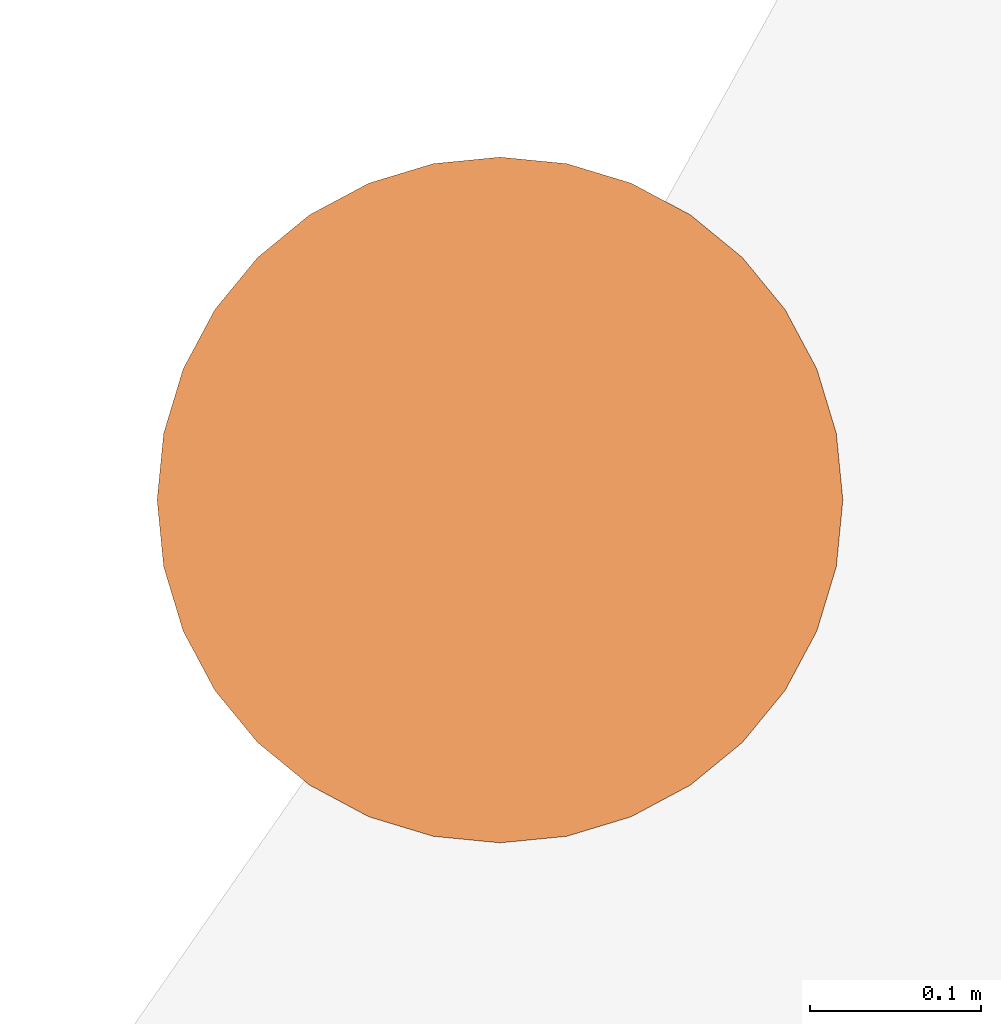
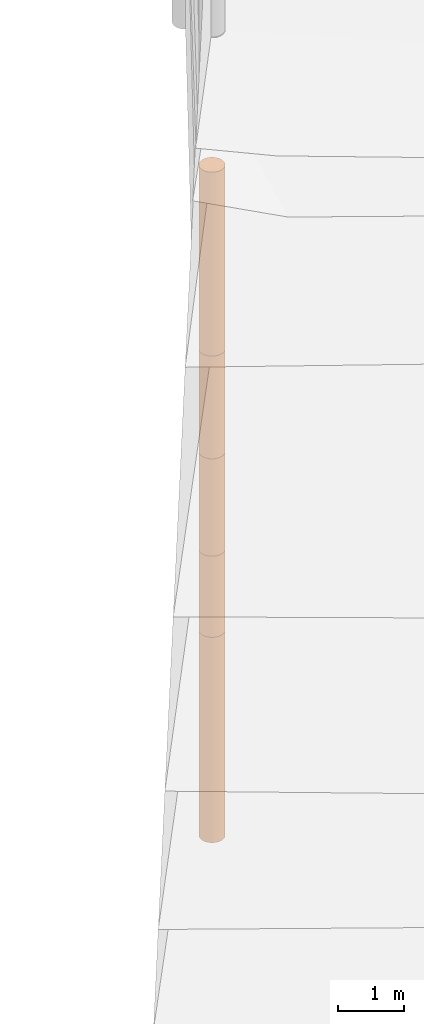
# One storey, part 8 of 24: 5 geographic elements.
"""IFC4 building model written with IfcOpenShell, lengths in metres."""

from ifc_helpers import new_model, entity, si_unit, converted_unit, frame, origin_with_axes, origin_2d_with_axis, place, context, subcontext, project, spatial, polygons, element, save


model = new_model("IFC4")

# Units and contexts
model_context = context("Model", 3, precision=1e-05, world=origin_with_axes())
plan_context = context("Plan", 2, precision=1e-05, world=origin_2d_with_axis())
body_context = subcontext(model_context, "Body", "Model", "MODEL_VIEW")
ifc_project = project(units=[converted_unit("PLANEANGLEUNIT", "degree", entity("IfcReal", 0.0174532925199433), si_unit("PLANEANGLEUNIT", "RADIAN"), dimensions=[0, 0, 0, 0, 0, 0, 0]), si_unit("AREAUNIT", "SQUARE_METRE"), si_unit("VOLUMEUNIT", "CUBIC_METRE"), si_unit("LENGTHUNIT", "METRE")], contexts=[model_context, plan_context])

# Site, building, storey
site_placement = place(None, origin_with_axes())
site = spatial("IfcSite", under=ifc_project, at=site_placement)
building_placement = place(site_placement, origin_with_axes())
building = spatial("IfcBuilding", under=site, at=building_placement, Name="Building")
storey_placement = place(building_placement, origin_with_axes())
storey = spatial("IfcBuildingStorey", under=building, at=storey_placement, Name="Storey")

# Geographic elements
geographic_element_1_placement = place(storey_placement, frame((-10.8999996185303, 35.5, -7.00000047683716), z_axis=(0.0, 0.0, 1.0), x_axis=(1.0, 0.0, 0.0)))
element("IfcGeographicElement", 1, at=geographic_element_1_placement, inside=storey, PredefinedType="NOTDEFINED", context=body_context, shape_type="Tessellation", body=[
    polygons([(0.0, 0.0, -1.89999985694885), (0.0390180610120296, 0.196157038211823, -1.89999985694885), (0.0, 0.199999988079071, -1.89999985694885), (0.0, 0.0, 1.89999985694885), (0.0, 0.199999988079071, 1.89999985694885), (0.0390180610120296, 0.196157038211823, 1.89999985694885), (0.0765366926789284, 0.18477588891983, -1.89999985694885), (0.0765366926789284, 0.18477588891983, 1.89999985694885), (0.111114047467709, 0.166293919086456, -1.89999985694885), (0.111114047467709, 0.166293919086456, 1.89999985694885), (0.141421362757683, 0.141421362757683, -1.89999985694885), (0.141421362757683, 0.141421362757683, 1.89999985694885), (0.166293919086456, 0.111114047467709, -1.89999985694885), (0.166293919086456, 0.111114047467709, 1.89999985694885), (0.18477588891983, 0.0765366926789284, -1.89999985694885), (0.18477588891983, 0.0765366926789284, 1.89999985694885), (0.196157038211823, 0.0390180610120296, -1.89999985694885), (0.196157038211823, 0.0390180610120296, 1.89999985694885), (0.199999988079071, 0.0, -1.89999985694885), (0.199999988079071, 0.0, 1.89999985694885), (0.196157038211823, -0.0390180610120296, -1.89999985694885), (0.196157038211823, -0.0390180610120296, 1.89999985694885), (0.18477588891983, -0.0765366926789284, -1.89999985694885), (0.18477588891983, -0.0765366926789284, 1.89999985694885), (0.166293919086456, -0.111114047467709, -1.89999985694885), (0.166293919086456, -0.111114047467709, 1.89999985694885), (0.141421362757683, -0.141421362757683, -1.89999985694885), (0.141421362757683, -0.141421362757683, 1.89999985694885), (0.111114047467709, -0.166293919086456, -1.89999985694885), (0.111114047467709, -0.166293919086456, 1.89999985694885), (0.0765366926789284, -0.18477588891983, -1.89999985694885), (0.0765366926789284, -0.18477588891983, 1.89999985694885), (0.0390180610120296, -0.196157038211823, -1.89999985694885), (0.0390180610120296, -0.196157038211823, 1.89999985694885), (0.0, -0.199999988079071, -1.89999985694885), (0.0, -0.199999988079071, 1.89999985694885), (-0.0390180610120296, -0.196157038211823, -1.89999985694885), (-0.0390180610120296, -0.196157038211823, 1.89999985694885), (-0.0765366926789284, -0.18477588891983, -1.89999985694885), (-0.0765366926789284, -0.18477588891983, 1.89999985694885), (-0.111114047467709, -0.166293919086456, -1.89999985694885), (-0.111114047467709, -0.166293919086456, 1.89999985694885), (-0.141421362757683, -0.141421362757683, -1.89999985694885), (-0.141421362757683, -0.141421362757683, 1.89999985694885), (-0.166293919086456, -0.111114047467709, -1.89999985694885), (-0.166293919086456, -0.111114047467709, 1.89999985694885), (-0.18477588891983, -0.0765366926789284, -1.89999985694885), (-0.18477588891983, -0.0765366926789284, 1.89999985694885), (-0.196157038211823, -0.0390180610120296, -1.89999985694885), (-0.196157038211823, -0.0390180610120296, 1.89999985694885), (-0.199999988079071, 0.0, -1.89999985694885), (-0.199999988079071, 0.0, 1.89999985694885), (-0.196157038211823, 0.0390180610120296, -1.89999985694885), (-0.196157038211823, 0.0390180610120296, 1.89999985694885), (-0.18477588891983, 0.0765366926789284, -1.89999985694885), (-0.18477588891983, 0.0765366926789284, 1.89999985694885), (-0.166293919086456, 0.111114047467709, -1.89999985694885), (-0.166293919086456, 0.111114047467709, 1.89999985694885), (-0.141421362757683, 0.141421362757683, -1.89999985694885), (-0.141421362757683, 0.141421362757683, 1.89999985694885), (-0.111114047467709, 0.166293919086456, -1.89999985694885), (-0.111114047467709, 0.166293919086456, 1.89999985694885), (-0.0765366926789284, 0.18477588891983, -1.89999985694885), (-0.0765366926789284, 0.18477588891983, 1.89999985694885), (-0.0390180610120296, 0.196157038211823, -1.89999985694885), (-0.0390180610120296, 0.196157038211823, 1.89999985694885)], [[[3, 2, 1]], [[6, 5, 4]], [[34, 36, 35, 33]], [[2, 7, 1]], [[8, 6, 4]], [[36, 38, 37, 35]], [[7, 9, 1]], [[10, 8, 4]], [[56, 58, 57, 55]], [[9, 11, 1]], [[12, 10, 4]], [[58, 60, 59, 57]], [[11, 13, 1]], [[12, 4, 14]], [[8, 10, 9, 7]], [[1, 13, 15]], [[4, 16, 14]], [[10, 12, 11, 9]], [[1, 15, 17]], [[16, 4, 18]], [[18, 20, 19, 17]], [[1, 17, 19]], [[4, 20, 18]], [[20, 22, 21, 19]], [[1, 19, 21]], [[4, 22, 20]], [[22, 24, 23, 21]], [[1, 21, 23]], [[4, 24, 22]], [[38, 40, 39, 37]], [[1, 23, 25]], [[4, 26, 24]], [[40, 42, 41, 39]], [[27, 1, 25]], [[26, 4, 28]], [[24, 26, 25, 23]], [[1, 27, 29]], [[28, 4, 30]], [[62, 64, 63, 61]], [[1, 29, 31]], [[4, 32, 30]], [[28, 30, 29, 27]], [[1, 31, 33]], [[4, 34, 32]], [[5, 6, 2, 3]], [[1, 33, 35]], [[4, 36, 34]], [[30, 32, 31, 29]], [[1, 35, 37]], [[4, 38, 36]], [[32, 34, 33, 31]], [[1, 37, 39]], [[4, 40, 38]], [[6, 8, 7, 2]], [[1, 39, 41]], [[4, 42, 40]], [[42, 44, 43, 41]], [[43, 1, 41]], [[4, 44, 42]], [[44, 46, 45, 43]], [[45, 1, 43]], [[46, 44, 4]], [[46, 48, 47, 45]], [[45, 47, 1]], [[48, 46, 4]], [[60, 62, 61, 59]], [[47, 49, 1]], [[4, 50, 48]], [[16, 18, 17, 15]], [[49, 51, 1]], [[52, 50, 4]], [[48, 50, 49, 47]], [[51, 53, 1]], [[54, 52, 4]], [[66, 5, 3, 65]], [[55, 1, 53]], [[56, 54, 4]], [[52, 54, 53, 51]], [[55, 57, 1]], [[58, 56, 4]], [[57, 59, 1]], [[60, 58, 4]], [[12, 14, 13, 11]], [[59, 61, 1]], [[62, 60, 4]], [[14, 16, 15, 13]], [[61, 63, 1]], [[64, 62, 4]], [[26, 28, 27, 25]], [[63, 65, 1]], [[66, 64, 4]], [[54, 56, 55, 53]], [[65, 3, 1]], [[5, 66, 4]], [[50, 52, 51, 49]], [[64, 66, 65, 63]]]),
])
geographic_element_2_placement = place(storey_placement, frame((-10.8999996185303, 35.5, -4.35000038146973), z_axis=(0.0, 0.0, 1.0), x_axis=(1.0, 0.0, 0.0)))
element("IfcGeographicElement", 2, at=geographic_element_2_placement, inside=storey, PredefinedType="NOTDEFINED", context=body_context, shape_type="Tessellation", body=[
    polygons([(0.0, 0.0, -0.749999940395355), (0.0390180610120296, 0.196157038211823, -0.749999940395355), (0.0, 0.199999988079071, -0.749999940395355), (0.0, 0.0, 0.749999940395355), (0.0, 0.199999988079071, 0.749999940395355), (0.0390180610120296, 0.196157038211823, 0.749999940395355), (0.0765366926789284, 0.18477588891983, -0.749999940395355), (0.0765366926789284, 0.18477588891983, 0.749999940395355), (0.111114047467709, 0.166293919086456, -0.749999940395355), (0.111114047467709, 0.166293919086456, 0.749999940395355), (0.141421362757683, 0.141421362757683, -0.749999940395355), (0.141421362757683, 0.141421362757683, 0.749999940395355), (0.166293919086456, 0.111114047467709, -0.749999940395355), (0.166293919086456, 0.111114047467709, 0.749999940395355), (0.18477588891983, 0.0765366926789284, -0.749999940395355), (0.18477588891983, 0.0765366926789284, 0.749999940395355), (0.196157038211823, 0.0390180610120296, -0.749999940395355), (0.196157038211823, 0.0390180610120296, 0.749999940395355), (0.199999988079071, 0.0, -0.749999940395355), (0.199999988079071, 0.0, 0.749999940395355), (0.196157038211823, -0.0390180610120296, -0.749999940395355), (0.196157038211823, -0.0390180610120296, 0.749999940395355), (0.18477588891983, -0.0765366926789284, -0.749999940395355), (0.18477588891983, -0.0765366926789284, 0.749999940395355), (0.166293919086456, -0.111114047467709, -0.749999940395355), (0.166293919086456, -0.111114047467709, 0.749999940395355), (0.141421362757683, -0.141421362757683, -0.749999940395355), (0.141421362757683, -0.141421362757683, 0.749999940395355), (0.111114047467709, -0.166293919086456, -0.749999940395355), (0.111114047467709, -0.166293919086456, 0.749999940395355), (0.0765366926789284, -0.18477588891983, -0.749999940395355), (0.0765366926789284, -0.18477588891983, 0.749999940395355), (0.0390180610120296, -0.196157038211823, -0.749999940395355), (0.0390180610120296, -0.196157038211823, 0.749999940395355), (0.0, -0.199999988079071, -0.749999940395355), (0.0, -0.199999988079071, 0.749999940395355), (-0.0390180610120296, -0.196157038211823, -0.749999940395355), (-0.0390180610120296, -0.196157038211823, 0.749999940395355), (-0.0765366926789284, -0.18477588891983, -0.749999940395355), (-0.0765366926789284, -0.18477588891983, 0.749999940395355), (-0.111114047467709, -0.166293919086456, -0.749999940395355), (-0.111114047467709, -0.166293919086456, 0.749999940395355), (-0.141421362757683, -0.141421362757683, -0.749999940395355), (-0.141421362757683, -0.141421362757683, 0.749999940395355), (-0.166293919086456, -0.111114047467709, -0.749999940395355), (-0.166293919086456, -0.111114047467709, 0.749999940395355), (-0.18477588891983, -0.0765366926789284, -0.749999940395355), (-0.18477588891983, -0.0765366926789284, 0.749999940395355), (-0.196157038211823, -0.0390180610120296, -0.749999940395355), (-0.196157038211823, -0.0390180610120296, 0.749999940395355), (-0.199999988079071, 0.0, -0.749999940395355), (-0.199999988079071, 0.0, 0.749999940395355), (-0.196157038211823, 0.0390180610120296, -0.749999940395355), (-0.196157038211823, 0.0390180610120296, 0.749999940395355), (-0.18477588891983, 0.0765366926789284, -0.749999940395355), (-0.18477588891983, 0.0765366926789284, 0.749999940395355), (-0.166293919086456, 0.111114047467709, -0.749999940395355), (-0.166293919086456, 0.111114047467709, 0.749999940395355), (-0.141421362757683, 0.141421362757683, -0.749999940395355), (-0.141421362757683, 0.141421362757683, 0.749999940395355), (-0.111114047467709, 0.166293919086456, -0.749999940395355), (-0.111114047467709, 0.166293919086456, 0.749999940395355), (-0.0765366926789284, 0.18477588891983, -0.749999940395355), (-0.0765366926789284, 0.18477588891983, 0.749999940395355), (-0.0390180610120296, 0.196157038211823, -0.749999940395355), (-0.0390180610120296, 0.196157038211823, 0.749999940395355)], [[[3, 2, 1]], [[6, 5, 4]], [[28, 30, 29, 27]], [[2, 7, 1]], [[8, 6, 4]], [[36, 38, 37, 35]], [[7, 9, 1]], [[10, 8, 4]], [[56, 58, 57, 55]], [[9, 11, 1]], [[12, 10, 4]], [[58, 60, 59, 57]], [[11, 13, 1]], [[12, 4, 14]], [[54, 56, 55, 53]], [[1, 13, 15]], [[4, 16, 14]], [[10, 12, 11, 9]], [[1, 15, 17]], [[4, 18, 16]], [[60, 62, 61, 59]], [[1, 17, 19]], [[4, 20, 18]], [[16, 18, 17, 15]], [[1, 19, 21]], [[20, 4, 22]], [[18, 20, 19, 17]], [[1, 21, 23]], [[4, 24, 22]], [[20, 22, 21, 19]], [[1, 23, 25]], [[24, 4, 26]], [[22, 24, 23, 21]], [[1, 25, 27]], [[26, 4, 28]], [[24, 26, 25, 23]], [[1, 27, 29]], [[28, 4, 30]], [[62, 64, 63, 61]], [[1, 29, 31]], [[4, 32, 30]], [[64, 66, 65, 63]], [[1, 31, 33]], [[4, 34, 32]], [[30, 32, 31, 29]], [[1, 33, 35]], [[4, 36, 34]], [[8, 10, 9, 7]], [[1, 35, 37]], [[4, 38, 36]], [[32, 34, 33, 31]], [[1, 37, 39]], [[4, 40, 38]], [[6, 8, 7, 2]], [[1, 39, 41]], [[4, 42, 40]], [[38, 40, 39, 37]], [[43, 1, 41]], [[4, 44, 42]], [[40, 42, 41, 39]], [[45, 1, 43]], [[4, 46, 44]], [[42, 44, 43, 41]], [[47, 1, 45]], [[48, 46, 4]], [[44, 46, 45, 43]], [[47, 49, 1]], [[50, 48, 4]], [[46, 48, 47, 45]], [[51, 1, 49]], [[52, 50, 4]], [[48, 50, 49, 47]], [[51, 53, 1]], [[4, 54, 52]], [[66, 5, 3, 65]], [[53, 55, 1]], [[56, 54, 4]], [[52, 54, 53, 51]], [[55, 57, 1]], [[4, 58, 56]], [[59, 1, 57]], [[60, 58, 4]], [[34, 36, 35, 33]], [[59, 61, 1]], [[62, 60, 4]], [[14, 16, 15, 13]], [[61, 63, 1]], [[64, 62, 4]], [[26, 28, 27, 25]], [[63, 65, 1]], [[66, 64, 4]], [[5, 6, 2, 3]], [[65, 3, 1]], [[5, 66, 4]], [[50, 52, 51, 49]], [[12, 14, 13, 11]]]),
])
geographic_element_3_placement = place(storey_placement, frame((-10.8999996185303, 35.5, -2.70000028610229), z_axis=(0.0, 0.0, 1.0), x_axis=(1.0, 0.0, 0.0)))
element("IfcGeographicElement", 3, at=geographic_element_3_placement, inside=storey, PredefinedType="NOTDEFINED", context=body_context, shape_type="Tessellation", body=[
    polygons([(0.0, 0.0, -0.899999916553497), (0.0390180610120296, 0.196157038211823, -0.899999916553497), (0.0, 0.199999988079071, -0.899999916553497), (0.0, 0.0, 0.899999916553497), (0.0, 0.199999988079071, 0.899999916553497), (0.0390180610120296, 0.196157038211823, 0.899999916553497), (0.0765366926789284, 0.18477588891983, -0.899999916553497), (0.0765366926789284, 0.18477588891983, 0.899999916553497), (0.111114047467709, 0.166293919086456, -0.899999916553497), (0.111114047467709, 0.166293919086456, 0.899999916553497), (0.141421362757683, 0.141421362757683, -0.899999916553497), (0.141421362757683, 0.141421362757683, 0.899999916553497), (0.166293919086456, 0.111114047467709, -0.899999916553497), (0.166293919086456, 0.111114047467709, 0.899999916553497), (0.18477588891983, 0.0765366926789284, -0.899999916553497), (0.18477588891983, 0.0765366926789284, 0.899999916553497), (0.196157038211823, 0.0390180610120296, -0.899999916553497), (0.196157038211823, 0.0390180610120296, 0.899999916553497), (0.199999988079071, 0.0, -0.899999916553497), (0.199999988079071, 0.0, 0.899999916553497), (0.196157038211823, -0.0390180610120296, -0.899999916553497), (0.196157038211823, -0.0390180610120296, 0.899999916553497), (0.18477588891983, -0.0765366926789284, -0.899999916553497), (0.18477588891983, -0.0765366926789284, 0.899999916553497), (0.166293919086456, -0.111114047467709, -0.899999916553497), (0.166293919086456, -0.111114047467709, 0.899999916553497), (0.141421362757683, -0.141421362757683, -0.899999916553497), (0.141421362757683, -0.141421362757683, 0.899999916553497), (0.111114047467709, -0.166293919086456, -0.899999916553497), (0.111114047467709, -0.166293919086456, 0.899999916553497), (0.0765366926789284, -0.18477588891983, -0.899999916553497), (0.0765366926789284, -0.18477588891983, 0.899999916553497), (0.0390180610120296, -0.196157038211823, -0.899999916553497), (0.0390180610120296, -0.196157038211823, 0.899999916553497), (0.0, -0.199999988079071, -0.899999916553497), (0.0, -0.199999988079071, 0.899999916553497), (-0.0390180610120296, -0.196157038211823, -0.899999916553497), (-0.0390180610120296, -0.196157038211823, 0.899999916553497), (-0.0765366926789284, -0.18477588891983, -0.899999916553497), (-0.0765366926789284, -0.18477588891983, 0.899999916553497), (-0.111114047467709, -0.166293919086456, -0.899999916553497), (-0.111114047467709, -0.166293919086456, 0.899999916553497), (-0.141421362757683, -0.141421362757683, -0.899999916553497), (-0.141421362757683, -0.141421362757683, 0.899999916553497), (-0.166293919086456, -0.111114047467709, -0.899999916553497), (-0.166293919086456, -0.111114047467709, 0.899999916553497), (-0.18477588891983, -0.0765366926789284, -0.899999916553497), (-0.18477588891983, -0.0765366926789284, 0.899999916553497), (-0.196157038211823, -0.0390180610120296, -0.899999916553497), (-0.196157038211823, -0.0390180610120296, 0.899999916553497), (-0.199999988079071, 0.0, -0.899999916553497), (-0.199999988079071, 0.0, 0.899999916553497), (-0.196157038211823, 0.0390180610120296, -0.899999916553497), (-0.196157038211823, 0.0390180610120296, 0.899999916553497), (-0.18477588891983, 0.0765366926789284, -0.899999916553497), (-0.18477588891983, 0.0765366926789284, 0.899999916553497), (-0.166293919086456, 0.111114047467709, -0.899999916553497), (-0.166293919086456, 0.111114047467709, 0.899999916553497), (-0.141421362757683, 0.141421362757683, -0.899999916553497), (-0.141421362757683, 0.141421362757683, 0.899999916553497), (-0.111114047467709, 0.166293919086456, -0.899999916553497), (-0.111114047467709, 0.166293919086456, 0.899999916553497), (-0.0765366926789284, 0.18477588891983, -0.899999916553497), (-0.0765366926789284, 0.18477588891983, 0.899999916553497), (-0.0390180610120296, 0.196157038211823, -0.899999916553497), (-0.0390180610120296, 0.196157038211823, 0.899999916553497)], [[[3, 2, 1]], [[6, 5, 4]], [[32, 34, 33, 31]], [[2, 7, 1]], [[8, 6, 4]], [[64, 66, 65, 63]], [[7, 9, 1]], [[10, 8, 4]], [[9, 11, 1]], [[12, 10, 4]], [[40, 42, 41, 39]], [[1, 11, 13]], [[12, 4, 14]], [[10, 12, 11, 9]], [[1, 13, 15]], [[4, 16, 14]], [[12, 14, 13, 11]], [[1, 15, 17]], [[16, 4, 18]], [[18, 20, 19, 17]], [[1, 17, 19]], [[4, 20, 18]], [[20, 22, 21, 19]], [[1, 19, 21]], [[4, 22, 20]], [[22, 24, 23, 21]], [[1, 21, 23]], [[22, 4, 24]], [[54, 56, 55, 53]], [[1, 23, 25]], [[4, 26, 24]], [[56, 58, 57, 55]], [[1, 25, 27]], [[4, 28, 26]], [[24, 26, 25, 23]], [[1, 27, 29]], [[28, 4, 30]], [[26, 28, 27, 25]], [[1, 29, 31]], [[4, 32, 30]], [[46, 48, 47, 45]], [[1, 31, 33]], [[4, 34, 32]], [[36, 38, 37, 35]], [[1, 33, 35]], [[4, 36, 34]], [[42, 44, 43, 41]], [[1, 35, 37]], [[4, 38, 36]], [[38, 40, 39, 37]], [[1, 37, 39]], [[4, 40, 38]], [[34, 36, 35, 33]], [[1, 39, 41]], [[4, 42, 40]], [[8, 10, 9, 7]], [[43, 1, 41]], [[4, 44, 42]], [[44, 46, 45, 43]], [[43, 45, 1]], [[4, 46, 44]], [[30, 32, 31, 29]], [[45, 47, 1]], [[48, 46, 4]], [[28, 30, 29, 27]], [[49, 1, 47]], [[4, 50, 48]], [[5, 6, 2, 3]], [[49, 51, 1]], [[52, 50, 4]], [[48, 50, 49, 47]], [[51, 53, 1]], [[54, 52, 4]], [[50, 52, 51, 49]], [[55, 1, 53]], [[4, 56, 54]], [[52, 54, 53, 51]], [[55, 57, 1]], [[58, 56, 4]], [[58, 60, 59, 57]], [[59, 1, 57]], [[60, 58, 4]], [[60, 62, 61, 59]], [[59, 61, 1]], [[62, 60, 4]], [[62, 64, 63, 61]], [[61, 63, 1]], [[64, 62, 4]], [[14, 16, 15, 13]], [[63, 65, 1]], [[66, 64, 4]], [[16, 18, 17, 15]], [[65, 3, 1]], [[5, 66, 4]], [[6, 8, 7, 2]], [[66, 5, 3, 65]]]),
])
geographic_element_4_placement = place(storey_placement, frame((-10.8999996185303, 35.5, -0.850000381469727), z_axis=(0.0, 0.0, 1.0), x_axis=(1.0, 0.0, 0.0)))
element("IfcGeographicElement", 4, at=geographic_element_4_placement, inside=storey, PredefinedType="NOTDEFINED", context=body_context, shape_type="Tessellation", body=[
    polygons([(0.0, 0.0, -0.949999928474426), (0.0390180610120296, 0.196157038211823, -0.949999928474426), (0.0, 0.199999988079071, -0.949999928474426), (0.0, 0.0, 0.949999928474426), (0.0, 0.199999988079071, 0.949999928474426), (0.0390180610120296, 0.196157038211823, 0.949999928474426), (0.0765366926789284, 0.18477588891983, -0.949999928474426), (0.0765366926789284, 0.18477588891983, 0.949999928474426), (0.111114047467709, 0.166293919086456, -0.949999928474426), (0.111114047467709, 0.166293919086456, 0.949999928474426), (0.141421362757683, 0.141421362757683, -0.949999928474426), (0.141421362757683, 0.141421362757683, 0.949999928474426), (0.166293919086456, 0.111114047467709, -0.949999928474426), (0.166293919086456, 0.111114047467709, 0.949999928474426), (0.18477588891983, 0.0765366926789284, -0.949999928474426), (0.18477588891983, 0.0765366926789284, 0.949999928474426), (0.196157038211823, 0.0390180610120296, -0.949999928474426), (0.196157038211823, 0.0390180610120296, 0.949999928474426), (0.199999988079071, 0.0, -0.949999928474426), (0.199999988079071, 0.0, 0.949999928474426), (0.196157038211823, -0.0390180610120296, -0.949999928474426), (0.196157038211823, -0.0390180610120296, 0.949999928474426), (0.18477588891983, -0.0765366926789284, -0.949999928474426), (0.18477588891983, -0.0765366926789284, 0.949999928474426), (0.166293919086456, -0.111114047467709, -0.949999928474426), (0.166293919086456, -0.111114047467709, 0.949999928474426), (0.141421362757683, -0.141421362757683, -0.949999928474426), (0.141421362757683, -0.141421362757683, 0.949999928474426), (0.111114047467709, -0.166293919086456, -0.949999928474426), (0.111114047467709, -0.166293919086456, 0.949999928474426), (0.0765366926789284, -0.18477588891983, -0.949999928474426), (0.0765366926789284, -0.18477588891983, 0.949999928474426), (0.0390180610120296, -0.196157038211823, -0.949999928474426), (0.0390180610120296, -0.196157038211823, 0.949999928474426), (0.0, -0.199999988079071, -0.949999928474426), (0.0, -0.199999988079071, 0.949999928474426), (-0.0390180610120296, -0.196157038211823, -0.949999928474426), (-0.0390180610120296, -0.196157038211823, 0.949999928474426), (-0.0765366926789284, -0.18477588891983, -0.949999928474426), (-0.0765366926789284, -0.18477588891983, 0.949999928474426), (-0.111114047467709, -0.166293919086456, -0.949999928474426), (-0.111114047467709, -0.166293919086456, 0.949999928474426), (-0.141421362757683, -0.141421362757683, -0.949999928474426), (-0.141421362757683, -0.141421362757683, 0.949999928474426), (-0.166293919086456, -0.111114047467709, -0.949999928474426), (-0.166293919086456, -0.111114047467709, 0.949999928474426), (-0.18477588891983, -0.0765366926789284, -0.949999928474426), (-0.18477588891983, -0.0765366926789284, 0.949999928474426), (-0.196157038211823, -0.0390180610120296, -0.949999928474426), (-0.196157038211823, -0.0390180610120296, 0.949999928474426), (-0.199999988079071, 0.0, -0.949999928474426), (-0.199999988079071, 0.0, 0.949999928474426), (-0.196157038211823, 0.0390180610120296, -0.949999928474426), (-0.196157038211823, 0.0390180610120296, 0.949999928474426), (-0.18477588891983, 0.0765366926789284, -0.949999928474426), (-0.18477588891983, 0.0765366926789284, 0.949999928474426), (-0.166293919086456, 0.111114047467709, -0.949999928474426), (-0.166293919086456, 0.111114047467709, 0.949999928474426), (-0.141421362757683, 0.141421362757683, -0.949999928474426), (-0.141421362757683, 0.141421362757683, 0.949999928474426), (-0.111114047467709, 0.166293919086456, -0.949999928474426), (-0.111114047467709, 0.166293919086456, 0.949999928474426), (-0.0765366926789284, 0.18477588891983, -0.949999928474426), (-0.0765366926789284, 0.18477588891983, 0.949999928474426), (-0.0390180610120296, 0.196157038211823, -0.949999928474426), (-0.0390180610120296, 0.196157038211823, 0.949999928474426)], [[[3, 2, 1]], [[6, 5, 4]], [[32, 34, 33, 31]], [[2, 7, 1]], [[8, 6, 4]], [[64, 66, 65, 63]], [[7, 9, 1]], [[10, 8, 4]], [[9, 11, 1]], [[12, 10, 4]], [[40, 42, 41, 39]], [[1, 11, 13]], [[12, 4, 14]], [[10, 12, 11, 9]], [[1, 13, 15]], [[4, 16, 14]], [[12, 14, 13, 11]], [[1, 15, 17]], [[16, 4, 18]], [[18, 20, 19, 17]], [[1, 17, 19]], [[4, 20, 18]], [[20, 22, 21, 19]], [[1, 19, 21]], [[4, 22, 20]], [[22, 24, 23, 21]], [[1, 21, 23]], [[4, 24, 22]], [[54, 56, 55, 53]], [[1, 23, 25]], [[4, 26, 24]], [[56, 58, 57, 55]], [[27, 1, 25]], [[4, 28, 26]], [[24, 26, 25, 23]], [[1, 27, 29]], [[28, 4, 30]], [[26, 28, 27, 25]], [[1, 29, 31]], [[4, 32, 30]], [[46, 48, 47, 45]], [[1, 31, 33]], [[4, 34, 32]], [[36, 38, 37, 35]], [[1, 33, 35]], [[4, 36, 34]], [[42, 44, 43, 41]], [[1, 35, 37]], [[4, 38, 36]], [[38, 40, 39, 37]], [[1, 37, 39]], [[4, 40, 38]], [[34, 36, 35, 33]], [[1, 39, 41]], [[4, 42, 40]], [[8, 10, 9, 7]], [[43, 1, 41]], [[4, 44, 42]], [[44, 46, 45, 43]], [[43, 45, 1]], [[46, 44, 4]], [[30, 32, 31, 29]], [[45, 47, 1]], [[48, 46, 4]], [[28, 30, 29, 27]], [[47, 49, 1]], [[4, 50, 48]], [[5, 6, 2, 3]], [[49, 51, 1]], [[52, 50, 4]], [[48, 50, 49, 47]], [[51, 53, 1]], [[54, 52, 4]], [[50, 52, 51, 49]], [[55, 1, 53]], [[56, 54, 4]], [[52, 54, 53, 51]], [[55, 57, 1]], [[58, 56, 4]], [[58, 60, 59, 57]], [[57, 59, 1]], [[60, 58, 4]], [[60, 62, 61, 59]], [[59, 61, 1]], [[62, 60, 4]], [[62, 64, 63, 61]], [[61, 63, 1]], [[64, 62, 4]], [[14, 16, 15, 13]], [[63, 65, 1]], [[66, 64, 4]], [[16, 18, 17, 15]], [[65, 3, 1]], [[5, 66, 4]], [[6, 8, 7, 2]], [[66, 5, 3, 65]]]),
])
geographic_element_5_placement = place(storey_placement, frame((-10.8999996185303, 35.5, 1.79999971389771), z_axis=(0.0, 0.0, 1.0), x_axis=(1.0, 0.0, 0.0)))
element("IfcGeographicElement", 5, at=geographic_element_5_placement, inside=storey, PredefinedType="NOTDEFINED", context=body_context, shape_type="Tessellation", body=[
    polygons([(0.0, 0.0, -1.70000004768372), (0.0390180610120296, 0.196157038211823, -1.70000004768372), (0.0, 0.199999988079071, -1.70000004768372), (0.0, 0.0, 1.70000004768372), (0.0, 0.199999988079071, 1.70000004768372), (0.0390180610120296, 0.196157038211823, 1.70000004768372), (0.0765366926789284, 0.18477588891983, -1.70000004768372), (0.0765366926789284, 0.18477588891983, 1.70000004768372), (0.111114047467709, 0.166293919086456, -1.70000004768372), (0.111114047467709, 0.166293919086456, 1.70000004768372), (0.141421362757683, 0.141421362757683, -1.70000004768372), (0.141421362757683, 0.141421362757683, 1.70000004768372), (0.166293919086456, 0.111114047467709, -1.70000004768372), (0.166293919086456, 0.111114047467709, 1.70000004768372), (0.18477588891983, 0.0765366926789284, -1.70000004768372), (0.18477588891983, 0.0765366926789284, 1.70000004768372), (0.196157038211823, 0.0390180610120296, -1.70000004768372), (0.196157038211823, 0.0390180610120296, 1.70000004768372), (0.199999988079071, 0.0, -1.70000004768372), (0.199999988079071, 0.0, 1.70000004768372), (0.196157038211823, -0.0390180610120296, -1.70000004768372), (0.196157038211823, -0.0390180610120296, 1.70000004768372), (0.18477588891983, -0.0765366926789284, -1.70000004768372), (0.18477588891983, -0.0765366926789284, 1.70000004768372), (0.166293919086456, -0.111114047467709, -1.70000004768372), (0.166293919086456, -0.111114047467709, 1.70000004768372), (0.141421362757683, -0.141421362757683, -1.70000004768372), (0.141421362757683, -0.141421362757683, 1.70000004768372), (0.111114047467709, -0.166293919086456, -1.70000004768372), (0.111114047467709, -0.166293919086456, 1.70000004768372), (0.0765366926789284, -0.18477588891983, -1.70000004768372), (0.0765366926789284, -0.18477588891983, 1.70000004768372), (0.0390180610120296, -0.196157038211823, -1.70000004768372), (0.0390180610120296, -0.196157038211823, 1.70000004768372), (0.0, -0.199999988079071, -1.70000004768372), (0.0, -0.199999988079071, 1.70000004768372), (-0.0390180610120296, -0.196157038211823, -1.70000004768372), (-0.0390180610120296, -0.196157038211823, 1.70000004768372), (-0.0765366926789284, -0.18477588891983, -1.70000004768372), (-0.0765366926789284, -0.18477588891983, 1.70000004768372), (-0.111114047467709, -0.166293919086456, -1.70000004768372), (-0.111114047467709, -0.166293919086456, 1.70000004768372), (-0.141421362757683, -0.141421362757683, -1.70000004768372), (-0.141421362757683, -0.141421362757683, 1.70000004768372), (-0.166293919086456, -0.111114047467709, -1.70000004768372), (-0.166293919086456, -0.111114047467709, 1.70000004768372), (-0.18477588891983, -0.0765366926789284, -1.70000004768372), (-0.18477588891983, -0.0765366926789284, 1.70000004768372), (-0.196157038211823, -0.0390180610120296, -1.70000004768372), (-0.196157038211823, -0.0390180610120296, 1.70000004768372), (-0.199999988079071, 0.0, -1.70000004768372), (-0.199999988079071, 0.0, 1.70000004768372), (-0.196157038211823, 0.0390180610120296, -1.70000004768372), (-0.196157038211823, 0.0390180610120296, 1.70000004768372), (-0.18477588891983, 0.0765366926789284, -1.70000004768372), (-0.18477588891983, 0.0765366926789284, 1.70000004768372), (-0.166293919086456, 0.111114047467709, -1.70000004768372), (-0.166293919086456, 0.111114047467709, 1.70000004768372), (-0.141421362757683, 0.141421362757683, -1.70000004768372), (-0.141421362757683, 0.141421362757683, 1.70000004768372), (-0.111114047467709, 0.166293919086456, -1.70000004768372), (-0.111114047467709, 0.166293919086456, 1.70000004768372), (-0.0765366926789284, 0.18477588891983, -1.70000004768372), (-0.0765366926789284, 0.18477588891983, 1.70000004768372), (-0.0390180610120296, 0.196157038211823, -1.70000004768372), (-0.0390180610120296, 0.196157038211823, 1.70000004768372)], [[[3, 2, 1]], [[6, 5, 4]], [[32, 34, 33, 31]], [[2, 7, 1]], [[8, 6, 4]], [[64, 66, 65, 63]], [[7, 9, 1]], [[10, 8, 4]], [[9, 11, 1]], [[12, 10, 4]], [[40, 42, 41, 39]], [[1, 11, 13]], [[12, 4, 14]], [[10, 12, 11, 9]], [[1, 13, 15]], [[14, 4, 16]], [[12, 14, 13, 11]], [[1, 15, 17]], [[4, 18, 16]], [[18, 20, 19, 17]], [[1, 17, 19]], [[4, 20, 18]], [[20, 22, 21, 19]], [[1, 19, 21]], [[20, 4, 22]], [[22, 24, 23, 21]], [[1, 21, 23]], [[4, 24, 22]], [[54, 56, 55, 53]], [[1, 23, 25]], [[4, 26, 24]], [[56, 58, 57, 55]], [[1, 25, 27]], [[4, 28, 26]], [[24, 26, 25, 23]], [[1, 27, 29]], [[28, 4, 30]], [[26, 28, 27, 25]], [[1, 29, 31]], [[4, 32, 30]], [[46, 48, 47, 45]], [[1, 31, 33]], [[4, 34, 32]], [[36, 38, 37, 35]], [[1, 33, 35]], [[4, 36, 34]], [[42, 44, 43, 41]], [[1, 35, 37]], [[4, 38, 36]], [[38, 40, 39, 37]], [[1, 37, 39]], [[4, 40, 38]], [[34, 36, 35, 33]], [[1, 39, 41]], [[4, 42, 40]], [[8, 10, 9, 7]], [[43, 1, 41]], [[4, 44, 42]], [[44, 46, 45, 43]], [[43, 45, 1]], [[4, 46, 44]], [[30, 32, 31, 29]], [[45, 47, 1]], [[4, 48, 46]], [[28, 30, 29, 27]], [[47, 49, 1]], [[50, 48, 4]], [[5, 6, 2, 3]], [[51, 1, 49]], [[52, 50, 4]], [[48, 50, 49, 47]], [[51, 53, 1]], [[4, 54, 52]], [[50, 52, 51, 49]], [[53, 55, 1]], [[56, 54, 4]], [[52, 54, 53, 51]], [[57, 1, 55]], [[58, 56, 4]], [[58, 60, 59, 57]], [[59, 1, 57]], [[60, 58, 4]], [[60, 62, 61, 59]], [[59, 61, 1]], [[62, 60, 4]], [[62, 64, 63, 61]], [[61, 63, 1]], [[64, 62, 4]], [[14, 16, 15, 13]], [[63, 65, 1]], [[66, 64, 4]], [[16, 18, 17, 15]], [[65, 3, 1]], [[5, 66, 4]], [[6, 8, 7, 2]], [[66, 5, 3, 65]]]),
])

save(model, "model.ifc")
